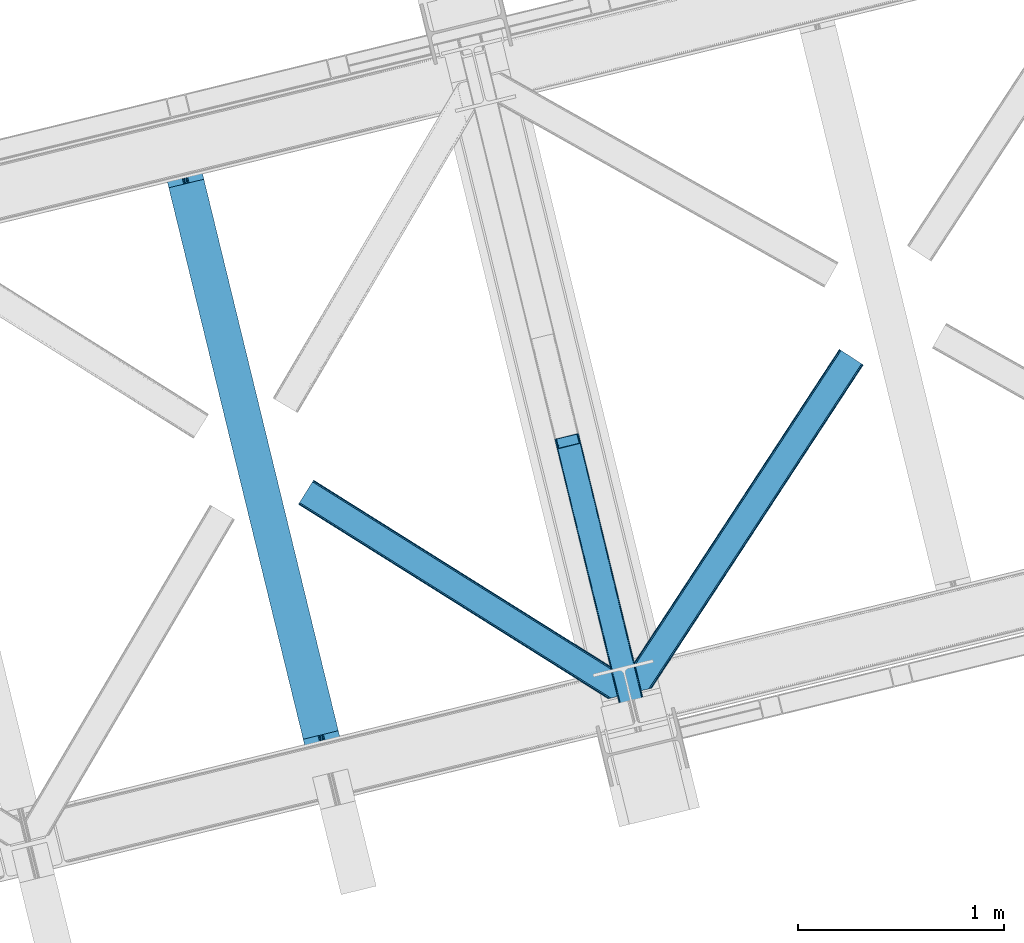
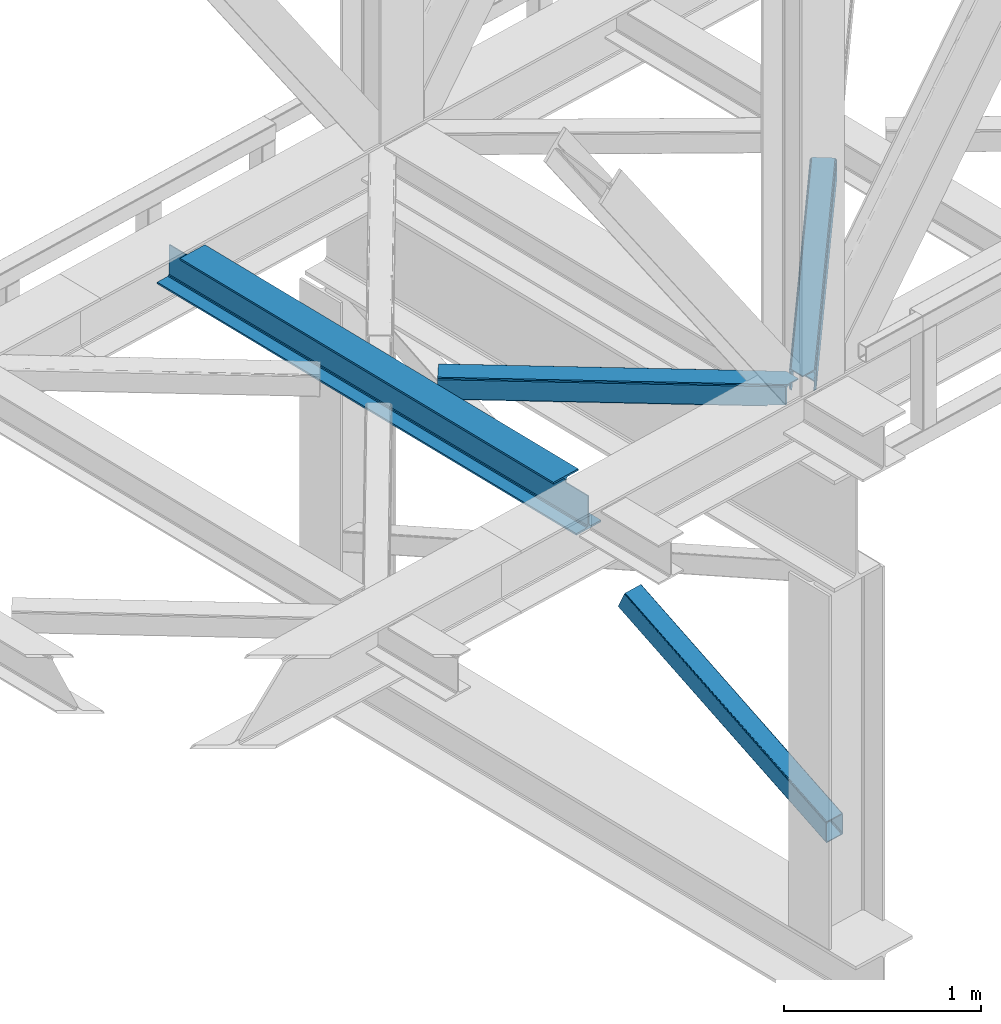
# One storey, part 37 of 92: 3 members, 1 beam.
"""IFC4 building model written with IfcOpenShell, lengths in millimetres."""

from ifc_helpers import new_model, entity, si_unit, converted_unit, derived_unit, direction, frame, origin, place, context, subcontext, project, spatial, triangles, polygons, material, type_object, element, save


model = new_model("IFC4")

# Units and contexts
model_context = context("Model", 3, precision=0.01, world=origin(), true_north=direction((6.12303176911189e-17, 1.0)))
plan_context = context("Plan", 3, precision=0.01, world=origin(), true_north=direction((6.12303176911189e-17, 1.0)))
body_context = subcontext(model_context, "Body", "Model", "MODEL_VIEW")
ifc_project = project(units=[si_unit("LENGTHUNIT", "METRE", prefix="MILLI"), si_unit("AREAUNIT", "SQUARE_METRE"), si_unit("VOLUMEUNIT", "CUBIC_METRE"), converted_unit("PLANEANGLEUNIT", "DEGREE", entity("IfcRatioMeasure", 0.0174532925199433), si_unit("PLANEANGLEUNIT", "RADIAN"), dimensions=[0, 0, 0, 0, 0, 0, 0]), si_unit("MASSUNIT", "GRAM", prefix="KILO"), derived_unit("MASSDENSITYUNIT", [(si_unit("MASSUNIT", "GRAM", prefix="KILO"), 1), (si_unit("LENGTHUNIT", "METRE"), -3)]), derived_unit("MOMENTOFINERTIAUNIT", [(si_unit("LENGTHUNIT", "METRE"), 4)]), si_unit("TIMEUNIT", "SECOND"), si_unit("FREQUENCYUNIT", "HERTZ"), si_unit("THERMODYNAMICTEMPERATUREUNIT", "DEGREE_CELSIUS"), derived_unit("THERMALTRANSMITTANCEUNIT", [(si_unit("MASSUNIT", "GRAM", prefix="KILO"), 1), (si_unit("THERMODYNAMICTEMPERATUREUNIT", "KELVIN"), -1), (si_unit("TIMEUNIT", "SECOND"), -3)]), derived_unit("VOLUMETRICFLOWRATEUNIT", [(si_unit("LENGTHUNIT", "METRE"), 3), (si_unit("TIMEUNIT", "SECOND"), -1)]), derived_unit("MASSFLOWRATEUNIT", [(si_unit("MASSUNIT", "GRAM", prefix="KILO"), 1), (si_unit("TIMEUNIT", "SECOND"), -1)]), derived_unit("ROTATIONALFREQUENCYUNIT", [(si_unit("TIMEUNIT", "SECOND"), -1)]), si_unit("ELECTRICCURRENTUNIT", "AMPERE"), si_unit("ELECTRICVOLTAGEUNIT", "VOLT"), si_unit("POWERUNIT", "WATT"), si_unit("FORCEUNIT", "NEWTON", prefix="KILO"), si_unit("ILLUMINANCEUNIT", "LUX"), si_unit("LUMINOUSFLUXUNIT", "LUMEN"), si_unit("LUMINOUSINTENSITYUNIT", "CANDELA"), derived_unit("USERDEFINED", [(si_unit("MASSUNIT", "GRAM", prefix="KILO"), -1), (si_unit("LENGTHUNIT", "METRE"), -2), (si_unit("TIMEUNIT", "SECOND"), 3), (si_unit("LUMINOUSFLUXUNIT", "LUMEN"), 1)]), derived_unit("LINEARVELOCITYUNIT", [(si_unit("LENGTHUNIT", "METRE"), 1), (si_unit("TIMEUNIT", "SECOND"), -1)]), si_unit("PRESSUREUNIT", "PASCAL"), derived_unit("USERDEFINED", [(si_unit("LENGTHUNIT", "METRE"), -2), (si_unit("MASSUNIT", "GRAM", prefix="KILO"), 1), (si_unit("TIMEUNIT", "SECOND"), -2)]), derived_unit("LINEARFORCEUNIT", [(si_unit("MASSUNIT", "GRAM", prefix="KILO"), 1), (si_unit("LENGTHUNIT", "METRE"), 1), (si_unit("TIMEUNIT", "SECOND"), -2), (si_unit("LENGTHUNIT", "METRE"), -1)]), derived_unit("PLANARFORCEUNIT", [(si_unit("MASSUNIT", "GRAM", prefix="KILO"), 1), (si_unit("LENGTHUNIT", "METRE"), 1), (si_unit("TIMEUNIT", "SECOND"), -2), (si_unit("LENGTHUNIT", "METRE"), -2)])], contexts=[model_context, plan_context])

# Site, building, storey
site_placement = place(None, origin())
site = spatial("IfcSite", under=ifc_project, at=site_placement, CompositionType="ELEMENT")
building_placement = place(site_placement, origin())
building = spatial("IfcBuilding", under=site, at=building_placement, CompositionType="ELEMENT")
storey_placement = place(building_placement, frame((0.0, 0.0, 15900.0)))
storey = spatial("IfcBuildingStorey", under=building, at=storey_placement, Name="05", CompositionType="ELEMENT", Elevation=15900.0)

# Beam
ifc_material = material(Name="Metal painted (White)")
beam_type = type_object("IfcBeamType", PredefinedType="BEAM")
beam_placement = place(storey_placement, frame((-50891.92, 5381.26, 3441.0)))
element("IfcBeam", 1, at=beam_placement, inside=storey, type_object=beam_type, material=ifc_material, ObjectType="Steel Beam", PredefinedType="BEAM", context=body_context, shape_type="Tessellation", body=[
    polygons([(900.98534618944, 41.4445662733081, 11.000000000004), (900.98534618944, 41.4445662733081, 2.16573425859679e-12), (170.021610174761, 3040.13999372697, 2.16573425859679e-12), (170.021610174761, 3040.13999372697, 11.000000000004), (834.919806235823, 25.3403919499656, 11.000000000004), (103.956070221144, 3024.03581940362, 11.000000000004), (828.971056214531, 23.8903211957385, 12.2179274798217), (98.0073201998513, 3022.5857486494, 12.2179274798217), (823.927949458422, 22.6610105689183, 15.6862915010192), (92.9642134437427, 3021.35643802258, 15.6862915010192), (820.558253255246, 21.8396114687119, 20.8770650821657), (89.5945172405668, 3020.53503892237, 20.8770650821657), (819.374973305552, 21.5511744621195, 27.0000000000047), (88.4112372908809, 3020.24660191578, 27.0000000000047), (81.6103728838888, 3018.58881926485, 27.0000000000047), (81.6103728838888, 3018.58881926485, 203.000000000006), (88.4112372908723, 3020.24660191578, 203.000000000006), (0.0, 2998.69542745366, 2.16573425859679e-12), (0.0, 2998.69542745366, 10.9999999999997), (66.0655399536172, 3014.799601777, 11.000000000004), (72.0142899749184, 3016.24967253123, 12.2179274798217), (77.057396731027, 3017.47898315805, 15.6862915010192), (80.4270929342029, 3018.30038225826, 20.8770650821657), (819.374973305552, 21.5511744621195, 203.000000000006), (812.574108898559, 19.8933918111876, 203.000000000006), (812.574108898559, 19.8933918111876, 27.0000000000047), (811.390828948873, 19.6049548045963, 20.8770650821657), (808.021132745689, 18.7835557043887, 15.6862915010192), (802.978025989589, 17.5542450775675, 12.2179274798217), (797.029275968288, 16.1041743233425, 11.000000000004), (730.963736014679, -1.08286712929839e-12, 10.9999999999997), (730.963736014679, -1.08286712929839e-12, 2.16573425859679e-12), (779.675212882749, 184.415062601691, 203.069791966819), (128.020401343512, 2857.75452019162, 203.000000000006), (128.243282132658, 2856.8401777572, 203.617301946336), (128.256196377177, 2856.7871977843, 217.000003693143), (779.530009633833, 185.010597404071, 217.000003676718), (779.530880241722, 185.007025963191, 204.00000679514), (772.96491171832, 182.385463974441, 203.006342981529), (772.742064056782, 183.299815969774, 203.617301946336), (772.729149812254, 183.352795942668, 217.000003693143), (121.455336555608, 2855.1293963229, 217.000003676718), (121.45446594771, 2855.13296776377, 204.00000679514), (121.310166358664, 2855.72494066435, 203.076120467494), (121.219536936511, 2856.09673754069, 203.000000000006), (780.713494357877, 185.298194377514, 223.122939328039), (784.082490766539, 186.122464201393, 228.313710402595), (789.125126170563, 187.353708426698, 231.782072735464), (795.073705041275, 188.80448128138, 232.999999602236), (861.13915590679, 204.909021065314, 232.999999283132), (861.137682570352, 204.915065042187, 243.999994005812), (691.116301666431, 163.469558245297, 243.999994827032), (691.117775002877, 163.463514268424, 233.000000104353), (757.183225868392, 179.568054052358, 232.999999785253), (763.132130996731, 181.017488520583, 231.782072861012), (768.175695503853, 182.244921343717, 228.313710479427), (771.546082413602, 183.063487001147, 223.12293937232), (120.271851831563, 2854.84179934945, 223.122939328039), (116.902855422893, 2854.01752952557, 228.313710402595), (111.860220018877, 2852.78628530027, 231.782072735464), (105.911641148165, 2851.33551244559, 232.999999602236), (39.8461902826419, 2835.23097266165, 232.999999283128), (39.8476636190794, 2835.22492868478, 243.999994005812), (209.869044522992, 2876.67043548167, 243.999994827032), (209.867571186554, 2876.67647945854, 233.000000104357), (143.802120321031, 2860.57193967461, 232.999999785253), (137.85321519271, 2859.12250520638, 231.782072861012), (132.809650685579, 2857.89507238325, 228.313710479427), (129.439263775838, 2857.07650672582, 223.12293937232)], [[[1, 2, 3, 4]], [[5, 1, 4, 6]], [[7, 5, 6, 8]], [[9, 7, 8, 10]], [[11, 9, 10, 12]], [[13, 11, 12, 14]], [[15, 16, 17, 14, 12, 10, 8, 6, 4, 3, 18, 19, 20, 21, 22, 23]], [[13, 24, 25, 26, 27, 28, 29, 30, 31, 32, 2, 1, 5, 7, 9, 11]], [[2, 32, 18, 3]], [[32, 31, 19, 18]], [[31, 30, 20, 19]], [[27, 26, 15, 23]], [[28, 27, 23, 22]], [[29, 28, 22, 21]], [[30, 29, 21, 20]], [[33, 24, 13, 14, 17, 34, 35, 36, 37, 38]], [[25, 39, 40, 41, 42, 43, 44, 16, 15, 26]], [[39, 25, 24, 33]], [[45, 34, 17, 16]], [[41, 40, 38, 37, 46, 47, 48, 49, 50, 51, 52, 53, 54, 55, 56, 57]], [[42, 58, 59, 60, 61, 62, 63, 64, 65, 66, 67, 68, 69, 36, 35, 43]], [[46, 37, 36, 69]], [[47, 46, 69, 68]], [[48, 47, 68, 67]], [[49, 48, 67, 66]], [[50, 49, 66, 65]], [[51, 50, 65, 64]], [[52, 51, 64, 63]], [[53, 52, 63, 62]], [[54, 53, 62, 61]], [[55, 54, 61, 60]], [[56, 55, 60, 59]], [[57, 56, 59, 58]], [[41, 57, 58, 42]]], closed=False),
])

# Members
member_type_1 = type_object("IfcMemberType", PredefinedType="BRACE")
member_1_placement = place(storey_placement, frame((-48982.34, 5508.87, 911.28)))
element("IfcMember", 2, at=member_1_placement, inside=storey, type_object=member_type_1, ObjectType="Steel Vertical Brace", PredefinedType="BRACE", context=body_context, shape_type="Tessellation", body=[
    triangles([(109.104968261716, 1516.67777252197, 692.224026489257), (472.287451171876, 26.761738586426, 0.0), (369.303039550781, 1.65803833007885, 0.0), (6.11590576171875, 1491.57407226563, 692.224026489257), (115.806884765625, 1516.48185424805, 696.163320922849), (116.583581542967, 1515.53714447022, 698.605032348631), (479.087036132813, 28.4191955566412, 7.68092651366896), (114.109313964844, 1517.03065795899, 694.092517089841), (478.091748046871, 28.1761871337894, 4.96481323242188), (111.755969238278, 1517.09925842285, 692.710043334959), (477.096459960936, 27.9337600708013, 2.24986267089844), (474.691955566406, 27.3477493286136, 1.12551269531104), (126.913183593751, 1473.16763763428, 795.217739868163), (479.087036132813, 28.4191955566412, 123.979641723632), (123.345959472652, 1469.55971832275, 801.112728881835), (120.797277832033, 1468.71209564209, 801.59758300781), (472.287451171876, 26.761738586426, 131.659405517577), (125.406298828122, 1470.70383453369, 799.729092407226), (474.691955566406, 27.3477493286136, 130.53505554199), (126.657385253908, 1471.97061767578, 797.659451293945), (477.096459960936, 27.9337600708013, 129.409542846679), (478.091748046871, 28.1761871337894, 126.694592285156), (369.303039550781, 1.65803833007885, 131.659405517577), (17.8082153320283, 1443.60839538574, 801.59758300781), (10.3296020507769, 1444.74844207764, 795.217739868163), (362.498803710936, 0.0, 123.979641723632), (363.494091796871, 0.243008422851744, 126.694592285156), (11.1062988281265, 1443.80431365967, 797.659451293945), (364.494030761714, 0.486016845703489, 129.409542846679), (12.7992187499985, 1443.25550994873, 799.729092407226), (366.898535156251, 1.07202758789117, 130.53505554199), (15.1572143554658, 1443.18690948486, 801.112728881835), (0.0, 1487.11853027344, 698.605032348631), (362.498803710936, 0.0, 7.68092651366896), (366.898535156251, 1.07202758789117, 1.12551269531104), (3.56722412109229, 1490.72644958496, 692.710043334959), (364.494030761714, 0.486016845703489, 2.24986267089844), (1.50688476562209, 1489.58233337402, 694.092517089841), (363.494091796871, 0.243008422851744, 4.96481323242188), (0.25579833984375, 1488.31496887207, 696.163320922849), (112.216406250001, 1512.35478057861, 703.161730957028), (111.43505859375, 1513.29949035645, 700.720019531247), (109.742138671871, 1513.84771270752, 698.650378417966), (104.733142089841, 1513.49482727051, 696.781887817382), (107.384143066403, 1513.91631317139, 697.266741943356), (120.057788085935, 1471.51831970215, 795.172393798828), (121.569323730466, 1473.98212280273, 790.661041259766), (121.313525390622, 1472.7856842041, 793.102752685547), (118.002099609374, 1470.37362213135, 796.55486755371), (115.448767089845, 1469.52599945068, 797.040884399412), (6.85539550780959, 1488.76784820557, 698.650378417966), (5.59965820312209, 1487.50048370361, 700.720019531247), (11.4644165039063, 1490.75958709717, 696.781887817382), (8.91108398437063, 1489.91254577637, 697.266741943356), (5.34385986327834, 1486.30404510498, 703.161730957028), (17.1710449218735, 1446.4384552002, 795.172393798828), (19.5290405273408, 1446.36985473633, 796.55486755371), (15.4781250000015, 1446.98667755127, 793.102752685547), (22.1800415039033, 1446.79075927734, 797.040884399412), (14.69677734375, 1447.9313873291, 790.661041259766), (371.754052734374, 2.2562576293949, 125.048181152342), (374.158557128903, 2.84226837158258, 126.173693847653), (369.349548339844, 1.66966552734448, 123.923831176755), (367.358972167967, 1.18423004150463, 118.492767333984), (368.354260253902, 1.42723846435547, 121.208880615231), (472.236291503905, 26.7495300292976, 123.923831176755), (467.427282714845, 25.5775085449222, 126.173693847653), (469.831787109375, 26.1635192871099, 125.048181152342), (473.231579589839, 26.9925384521484, 121.208880615231), (474.226867675781, 27.2349655151374, 118.492767333984), (369.349548339844, 1.66966552734448, 7.73557434081886), (371.754052734374, 2.2562576293949, 6.61122436523146), (367.358972167967, 1.18423004150463, 13.166638183593), (368.354260253902, 1.42723846435547, 10.4505249023423), (374.158557128903, 2.84226837158258, 5.48571166992042), (472.236291503905, 26.7495300292976, 7.73557434081886), (473.231579589839, 26.9925384521484, 10.4505249023423), (469.831787109375, 26.1635192871099, 6.61122436523146), (474.226867675781, 27.2349655151374, 13.166638183593), (467.427282714845, 25.5775085449222, 5.48571166992042)], [[1, 2, 3], [3, 4, 1], [5, 6, 7], [8, 5, 9], [10, 8, 11], [1, 10, 12], [12, 2, 1], [11, 12, 10], [9, 11, 8], [7, 9, 5], [6, 13, 14], [14, 7, 6], [15, 16, 17], [18, 15, 19], [20, 18, 21], [13, 20, 22], [22, 14, 13], [21, 22, 20], [19, 21, 18], [17, 19, 15], [17, 16, 23], [24, 23, 16], [25, 26, 27], [28, 27, 29], [30, 29, 31], [32, 31, 23], [23, 24, 32], [31, 32, 30], [29, 30, 28], [27, 28, 25], [25, 33, 26], [34, 26, 33], [4, 3, 35], [36, 35, 37], [38, 37, 39], [40, 39, 34], [34, 33, 40], [39, 40, 38], [37, 38, 36], [35, 36, 4], [41, 6, 42], [43, 5, 8], [8, 10, 43], [6, 41, 13], [6, 5, 43], [43, 42, 6], [44, 1, 4], [1, 45, 43], [44, 45, 1], [1, 43, 10], [18, 46, 15], [47, 13, 41], [46, 20, 13], [48, 13, 47], [20, 46, 18], [46, 16, 15], [13, 48, 46], [46, 49, 16], [16, 50, 24], [50, 16, 49], [51, 33, 52], [4, 53, 44], [54, 4, 51], [4, 54, 53], [51, 4, 36], [55, 52, 33], [36, 38, 51], [40, 51, 38], [55, 33, 25], [40, 33, 51], [56, 32, 24], [57, 56, 24], [58, 25, 56], [59, 24, 50], [24, 59, 57], [30, 32, 56], [25, 60, 55], [28, 56, 25], [60, 25, 58], [56, 28, 30], [61, 62, 23], [27, 63, 31], [27, 31, 29], [23, 62, 17], [23, 31, 61], [63, 61, 31], [64, 26, 34], [26, 65, 63], [64, 65, 26], [26, 63, 27], [19, 66, 22], [67, 17, 62], [68, 19, 17], [68, 17, 67], [22, 21, 19], [66, 14, 22], [19, 68, 66], [66, 69, 14], [14, 70, 7], [70, 14, 69], [71, 35, 72], [34, 73, 64], [74, 34, 71], [34, 74, 73], [71, 34, 39], [72, 3, 75], [71, 39, 35], [35, 39, 37], [75, 3, 2], [35, 3, 72], [76, 9, 7], [77, 76, 7], [78, 12, 76], [79, 7, 70], [7, 79, 77], [12, 9, 76], [2, 80, 75], [12, 78, 2], [80, 2, 78], [11, 9, 12], [80, 44, 75], [53, 75, 44], [44, 80, 78], [45, 78, 76], [43, 76, 77], [42, 77, 79], [79, 41, 42], [77, 42, 43], [76, 43, 45], [78, 45, 44], [47, 41, 70], [79, 70, 41], [47, 70, 69], [48, 69, 66], [46, 66, 68], [49, 68, 67], [67, 50, 49], [68, 49, 46], [66, 46, 48], [69, 48, 47], [50, 67, 59], [62, 59, 67], [57, 59, 62], [56, 57, 61], [58, 56, 63], [60, 58, 65], [65, 64, 60], [63, 65, 58], [61, 63, 56], [62, 61, 57], [55, 60, 64], [64, 73, 55], [52, 55, 73], [51, 52, 74], [54, 51, 71], [53, 54, 72], [72, 75, 53], [71, 72, 54], [74, 71, 51], [73, 74, 52]]),
])
member_type_2 = type_object("IfcMemberType", PredefinedType="BRACE")
member_2_placement = place(storey_placement, frame((-48630.06, 5769.52, 3511.0)))
element("IfcMember", 3, at=member_2_placement, inside=storey, type_object=member_type_2, ObjectType="Steel Horizontal Brace", PredefinedType="BRACE", context=body_context, shape_type="Tessellation", body=[
    triangles([(109.770043945311, 259.949830627442, 7.52047119140843), (115.030187988275, 238.365682983398, 7.77510681152489), (114.216284179682, 239.94640045166, 8.3320495605476), (108.807312011719, 259.662057495118, 8.52041015625218), (113.6349243164, 239.859777832031, 8.52041015625218), (112.207104492183, 237.677352905273, 8.52041015625218), (91.0363037109346, 232.516621398926, 8.52041015625218), (109.532849121089, 237.025648498535, 9.50058288574292), (90.2596069335923, 232.32767944336, 9.50058288574292), (5.01829833984084, 77.405158996582, 9.50058288574292), (0.62786865234375, 95.4308029174808, 9.50058288574292), (1046.62448730468, 1651.75324859619, 6.99957275390625), (1041.02017822265, 1655.42221069336, 8.3320495605476), (116.699853515624, 231.514356994629, 6.99957275390625), (1036.27163085937, 1658.53190460205, 12.1260040283232), (3.92999267578125, 81.8752349853512, 12.1260040283232), (1033.0950805664, 1660.61026611328, 17.8035644531265), (2.70216064452688, 86.9220199584961, 17.8035644531265), (1031.98352050781, 1661.3398727417, 24.4996673583992), (2.26962890624418, 88.6940048217775, 24.4996673583992), (1122.75472412109, 1601.90454711914, 6.99957275390625), (146.20968017578, 110.458955383301, 6.99957275390625), (1031.98352050781, 1661.3398727417, 115.501089477541), (2.26962890624418, 88.6940048217775, 115.501089477541), (1033.0950805664, 1660.61026611328, 122.196029663086), (2.70216064452688, 86.9220199584961, 122.196029663086), (1036.27163085937, 1658.53190460205, 127.87475280762), (3.92999267578125, 81.8752349853512, 127.87475280762), (1041.02017822265, 1655.42221069336, 131.667544555665), (5.77174072265188, 74.322789001465, 131.667544555665), (1046.62448730468, 1651.75324859619, 133.000021362306), (7.94370117186918, 65.4140304565426, 133.000021362306), (1027.23962402344, 1664.44433441162, 10.8028289794929), (0.520898437498545, 95.8714736938473, 10.8691040039084), (0.0, 98.0056457519531, 17.5000946044929), (1035.16472167968, 1659.2562789917, 1.33247680664135), (112.258264160155, 249.73533782959, 1.33247680664135), (110.542089843744, 256.771536254882, 5.59500732422021), (109.077062988275, 259.839372253418, 8.31925964355469), (1030.4161743164, 1662.36655426025, 5.12526855468968), (1040.76903076172, 1655.58789825439, 0.0), (114.430224609372, 240.826579284668, 0.0), (1026.12806396484, 1665.1745223999, 17.5000946044929), (1128.61018066406, 1598.06989746094, 0.0), (148.479309082031, 101.147314453125, 0.0), (150.651269531249, 92.2385559082031, 1.33247680664135), (148.507214355464, 101.029298400879, 8.50064392089917), (152.488366699217, 84.686109924316, 5.12526855468968), (153.344128417964, 81.1822540283201, 8.50064392089917), (1026.12806396484, 1665.1745223999, 122.500662231447), (0.0, 98.0056457519531, 122.500662231447), (1040.76903076172, 1655.58789825439, 139.999594116212), (1035.16472167968, 1659.2562789917, 138.667117309571), (3.50211181640043, 83.6350112915043, 138.667117309571), (5.674072265625, 74.7262527465818, 139.999594116212), (1030.4161743164, 1662.36655426025, 134.874325561526), (1.66036376952979, 91.1874572753904, 134.874325561526), (1027.23962402344, 1664.44433441162, 129.197927856447), (0.432531738275429, 96.2336608886717, 129.197927856447), (23.8869140624956, 0.0, 139.999594116212), (23.8869140624956, 0.0, 133.000021362306), (1128.61018066406, 1598.06989746094, 139.999594116212), (93.3338378906192, 16.9280364990236, 139.999594116212), (1122.75472412109, 1601.90454711914, 133.000021362306), (83.3763061523423, 14.5008590698244, 133.000021362306), (1143.25114746093, 1588.48385467529, 122.500662231447), (1142.13958740234, 1589.21346130371, 129.197927856447), (118.225341796875, 22.9951080322262, 122.500662231447), (116.327783203124, 22.5335083007813, 129.197927856447), (1138.96303710937, 1591.29182281494, 134.874325561526), (110.932763671874, 21.2184722900392, 134.874325561526), (1134.21448974609, 1594.4020980835, 138.667117309571), (102.858837890621, 19.2499877929686, 138.667117309571), (1143.25114746093, 1588.48385467529, 17.5000946044929), (118.225341796875, 22.9951080322262, 17.5000946044929), (1142.13958740234, 1589.21346130371, 10.8028289794929), (1133.1075805664, 1595.12647247314, 12.1260040283232), (1136.27947998047, 1593.04811096191, 17.8035644531265), (1137.39569091797, 1592.3185043335, 24.4996673583992), (1138.96303710937, 1591.29182281494, 5.12526855468968), (1134.21448974609, 1594.4020980835, 1.33247680664135), (1128.35903320312, 1598.23616638184, 8.3320495605476), (1133.1075805664, 1595.12647247314, 127.87475280762), (1137.39569091797, 1592.3185043335, 115.501089477541), (1136.27947998047, 1593.04811096191, 122.196029663086), (1128.35903320312, 1598.23616638184, 131.667544555665), (92.9013061523438, 16.8228103637693, 131.667544555665), (100.979882812499, 18.79129486084, 127.87475280762), (106.374902343749, 20.106330871582, 122.196029663086), (108.267810058591, 20.5685119628906, 115.501089477541), (108.267810058591, 20.5685119628906, 24.4996673583992), (100.979882812499, 18.79129486084, 12.1260040283232), (115.472021484369, 22.32421875, 9.50058288574292), (106.374902343749, 20.106330871582, 17.8035644531265), (96.1987792968721, 17.6262496948239, 9.50058288574292), (115.941760253903, 22.4393280029299, 10.8702667236357), (153.060424804688, 80.2392883300781, 9.00061340332104), (152.776721191403, 79.2969039916989, 9.50058288574292), (148.711853027344, 99.8677413940432, 8.8831787109375), (148.600231933589, 99.023606872559, 9.08781738281323), (148.493261718744, 98.1672637939455, 9.29478149414354), (148.381640624997, 97.3225479125977, 9.50058288574292)], [[1, 2, 3], [4, 5, 6], [6, 7, 4], [7, 6, 8], [8, 9, 7], [9, 8, 10], [10, 11, 9], [12, 13, 3], [3, 2, 12], [2, 14, 12], [15, 16, 8], [8, 13, 15], [8, 5, 13], [16, 10, 8], [8, 6, 5], [15, 17, 18], [18, 16, 15], [17, 19, 20], [20, 18, 17], [21, 12, 14], [14, 22, 21], [19, 23, 20], [24, 20, 23], [23, 25, 24], [26, 24, 25], [25, 27, 26], [28, 26, 27], [27, 29, 28], [30, 28, 29], [29, 31, 30], [32, 30, 31], [33, 34, 35], [36, 37, 38], [33, 4, 9], [33, 1, 39], [9, 34, 33], [9, 11, 34], [4, 7, 9], [40, 38, 1], [1, 33, 40], [38, 40, 36], [36, 41, 37], [42, 37, 41], [35, 43, 33], [41, 44, 42], [45, 42, 44], [14, 42, 22], [37, 2, 38], [2, 37, 42], [38, 2, 1], [42, 14, 2], [22, 42, 45], [46, 47, 45], [47, 46, 48], [45, 47, 22], [48, 49, 47], [50, 43, 35], [35, 51, 50], [52, 53, 54], [54, 55, 52], [53, 56, 57], [57, 54, 53], [56, 58, 59], [59, 57, 56], [58, 50, 51], [51, 59, 58], [28, 57, 26], [30, 32, 55], [32, 60, 55], [32, 61, 60], [54, 30, 55], [28, 54, 57], [16, 11, 10], [28, 30, 54], [51, 35, 20], [24, 26, 51], [24, 51, 20], [57, 59, 26], [26, 59, 51], [35, 18, 20], [18, 11, 16], [11, 18, 34], [35, 34, 18], [62, 55, 63], [62, 52, 55], [55, 60, 63], [64, 32, 31], [32, 64, 65], [61, 32, 65], [66, 67, 68], [69, 68, 67], [67, 70, 69], [71, 69, 70], [70, 72, 71], [73, 71, 72], [72, 62, 73], [63, 73, 62], [74, 66, 68], [68, 75, 74], [76, 77, 78], [79, 66, 74], [76, 78, 74], [76, 80, 77], [78, 79, 74], [77, 80, 81], [21, 44, 41], [44, 82, 81], [82, 44, 21], [82, 77, 81], [67, 83, 70], [84, 66, 79], [66, 85, 67], [85, 66, 84], [67, 85, 83], [62, 64, 52], [72, 70, 83], [83, 86, 72], [86, 64, 62], [62, 72, 86], [15, 36, 40], [41, 12, 21], [41, 13, 12], [13, 41, 36], [15, 13, 36], [19, 43, 50], [33, 17, 15], [40, 33, 15], [17, 33, 43], [19, 17, 43], [53, 27, 56], [52, 64, 31], [31, 29, 52], [29, 27, 53], [53, 52, 29], [58, 56, 27], [50, 23, 19], [25, 50, 58], [50, 25, 23], [25, 58, 27], [64, 86, 87], [87, 65, 64], [86, 83, 88], [88, 87, 86], [83, 85, 89], [89, 88, 83], [85, 84, 90], [90, 89, 85], [84, 79, 91], [91, 90, 84], [89, 68, 69], [87, 73, 63], [60, 65, 63], [65, 60, 61], [65, 87, 63], [88, 73, 87], [88, 89, 71], [71, 73, 88], [69, 71, 89], [91, 75, 68], [92, 93, 94], [89, 90, 68], [92, 95, 93], [91, 94, 75], [90, 91, 68], [96, 75, 94], [94, 93, 96], [76, 74, 75], [49, 80, 97], [98, 97, 80], [49, 48, 80], [76, 96, 98], [98, 80, 76], [96, 93, 98], [44, 81, 45], [46, 45, 81], [81, 80, 46], [48, 46, 80], [75, 96, 76], [82, 21, 22], [77, 82, 47], [47, 99, 77], [77, 100, 101], [100, 77, 99], [101, 102, 77], [77, 102, 92], [95, 92, 102], [22, 47, 82], [79, 78, 91], [94, 91, 78], [78, 77, 94], [92, 94, 77], [102, 101, 98], [101, 100, 97], [100, 99, 49], [99, 47, 49], [102, 98, 93], [93, 95, 102]]),
])
member_type_3 = type_object("IfcMemberType", PredefinedType="BRACE")
member_3_placement = place(storey_placement, frame((-50224.54, 5740.78, 3511.0)))
element("IfcMember", 4, at=member_3_placement, inside=storey, type_object=member_type_3, ObjectType="Steel Horizontal Brace", PredefinedType="BRACE", context=body_context, shape_type="Tessellation", body=[
    triangles([(9.3017578125, 956.602075195313, 0.0), (65.121606445311, 1045.5350189209, 0.0), (1381.50172119141, 219.29300994873, 0.0), (1417.17861328125, 72.9298507690428, 0.0), (1422.67130126953, 50.3934356689451, 10.8028289794929), (1423.12708740235, 48.5365722656252, 17.5000946044929), (0.0, 941.779724121094, 17.5000946044929), (0.706933593748545, 942.908143615723, 10.8028289794929), (1421.3830078125, 55.6809036254881, 5.12526855468968), (2.72076416015625, 946.121319580078, 5.12526855468968), (1419.45289306641, 63.5949554443359, 1.33247680664135), (5.73918457031687, 950.929747009277, 1.33247680664135), (68.6795288085923, 1051.20734710693, 1.33247680664135), (71.6979492187529, 1056.016355896, 5.12526855468968), (1377.30662841797, 236.497192382813, 5.17061462402489), (73.7164306640625, 1059.22895050049, 10.8028289794929), (1382.10168457031, 238.005239868164, 10.8028289794929), (1383.90622558594, 238.445329284668, 17.5000946044929), (74.423364257811, 1060.35736999512, 17.5000946044929), (1379.22744140625, 228.627905273437, 1.33247680664135), (1377.23221435547, 236.818103027344, 17.5198608398459), (1383.90622558594, 238.445329284668, 18.5197998046897), (1378.19959716797, 237.054716491699, 18.5197998046897), (1379.50649414062, 231.698066711426, 18.5197998046897), (1563.91384277344, 125.462109375, 18.5197998046897), (1566.64855957031, 114.236050415039, 18.5197998046897), (1563.91384277344, 125.462109375, 122.500662231447), (74.423364257811, 1060.35736999512, 122.500662231447), (1564.36497802735, 123.605245971679, 129.197927856447), (73.7164306640625, 1059.22895050049, 129.197927856447), (1565.65327148438, 118.317196655274, 134.874325561526), (71.6979492187529, 1056.016355896, 134.874325561526), (1567.58338623047, 110.403144836426, 138.667117309571), (68.6795288085923, 1051.20734710693, 138.667117309571), (1569.85766601563, 101.068249511719, 139.999594116212), (65.121606445311, 1045.5350189209, 139.999594116212), (67.9772460937529, 1050.08706665039, 12.1260040283232), (1379.67392578125, 226.784413146973, 12.1260040283232), (1378.42749023438, 231.905030822754, 17.5198608398459), (69.9957275390625, 1053.30024261475, 17.8035644531265), (1566.29044189453, 115.704565429687, 24.4996673583992), (70.702661132811, 1054.42866210938, 24.4996673583992), (1381.60404052735, 218.870361328125, 8.3320495605476), (64.9588256835923, 1045.27863922119, 8.3320495605476), (1383.8783203125, 209.535466003418, 6.99957275390625), (61.400903320311, 1039.60631103516, 6.99957275390625), (13.0224609375, 962.530783081054, 6.99957275390625), (1414.80201416016, 82.6873947143558, 6.99957275390625), (1419.00640869141, 65.4384475708011, 12.1260040283232), (1420.25284423828, 60.3178298950197, 17.5198608398459), (1417.07629394531, 73.3524993896481, 8.3320495605476), (1566.29044189453, 115.704565429687, 115.501089477541), (70.702661132811, 1054.42866210938, 115.501089477541), (1569.95998535156, 100.646182250976, 131.667544555665), (1572.23891601562, 91.3107055664059, 133.000021362306), (61.400903320311, 1039.60631103516, 133.000021362306), (64.9588256835923, 1045.27863922119, 131.667544555665), (1568.03452148438, 108.559652709961, 127.87475280762), (67.9772460937529, 1050.08706665039, 127.87475280762), (1566.74157714844, 113.847702026367, 122.196029663086), (69.9957275390625, 1053.30024261475, 122.196029663086), (1589.21927490235, 21.6376327514645, 133.000021362306), (1589.21927490235, 21.6376327514645, 139.999594116212), (9.3017578125, 956.602075195313, 139.999594116212), (1524.16278076172, 5.77929840087927, 139.999594116212), (1515.09356689453, 3.56780548095685, 138.667117309571), (5.73918457031687, 950.929747009277, 138.667117309571), (1507.4010131836, 1.69291992187482, 134.874325561526), (2.72076416015625, 946.121319580078, 134.874325561526), (1502.26179199219, 0.439508056640989, 129.197927856447), (0.706933593748545, 942.908143615723, 129.197927856447), (1500.45260009765, 0.0, 122.500662231447), (0.0, 941.779724121094, 122.500662231447), (1424.34096679687, 47.7738281250004, 18.5197998046897), (1500.45260009765, 0.0, 18.5197998046897), (1421.60625, 58.9993057250977, 18.5197998046897), (1511.36821289063, 2.65972137451172, 18.5197998046897), (3.720703125, 947.708432006836, 24.4996673583992), (1509.9403930664, 2.31148681640661, 24.4996673583992), (4.42763671874854, 948.836851501464, 17.8035644531265), (1420.92722167969, 59.6585678100582, 18.0198303222678), (6.44611816406541, 952.050027465821, 12.1260040283232), (9.45988769531687, 956.858454895019, 8.3320495605476), (6.44611816406541, 952.050027465821, 127.87475280762), (13.0224609375, 962.530783081054, 133.000021362306), (9.45988769531687, 956.858454895019, 131.667544555665), (3.720703125, 947.708432006836, 115.501089477541), (4.42763671874854, 948.836851501464, 122.196029663086), (1524.57670898438, 5.87929229736346, 131.667544555665), (1516.88415527344, 4.00440673828143, 127.87475280762), (1511.74493408203, 2.75157623291034, 122.196029663086), (1533.65057373047, 8.09136657714862, 133.000021362306), (1509.9403930664, 2.31148681640661, 115.501089477541)], [[1, 2, 3], [3, 4, 1], [5, 6, 7], [7, 8, 5], [9, 5, 8], [8, 10, 9], [11, 9, 10], [10, 12, 11], [4, 11, 12], [12, 1, 4], [13, 14, 15], [16, 17, 15], [15, 14, 16], [18, 17, 19], [16, 19, 17], [20, 3, 2], [2, 13, 20], [15, 20, 13], [18, 21, 17], [18, 22, 23], [17, 21, 15], [21, 18, 23], [24, 22, 25], [22, 24, 23], [25, 26, 24], [25, 22, 27], [19, 22, 18], [22, 28, 27], [19, 28, 22], [29, 27, 30], [28, 30, 27], [31, 29, 32], [30, 32, 29], [33, 31, 34], [32, 34, 31], [35, 33, 36], [34, 36, 33], [37, 38, 39], [39, 40, 37], [24, 41, 42], [24, 26, 41], [42, 40, 39], [43, 38, 44], [37, 44, 38], [45, 43, 46], [44, 46, 43], [46, 47, 45], [48, 45, 47], [3, 48, 4], [43, 20, 38], [39, 15, 21], [15, 39, 38], [38, 20, 15], [43, 3, 20], [3, 45, 48], [43, 45, 3], [9, 49, 50], [50, 5, 9], [6, 5, 50], [49, 11, 51], [51, 4, 48], [4, 51, 11], [49, 9, 11], [41, 52, 53], [53, 42, 41], [54, 55, 56], [56, 57, 54], [58, 54, 57], [57, 59, 58], [60, 58, 59], [59, 61, 60], [52, 60, 61], [61, 53, 52], [58, 31, 33], [58, 33, 54], [55, 54, 35], [60, 31, 58], [62, 55, 63], [35, 63, 55], [54, 33, 35], [29, 31, 60], [25, 27, 52], [41, 25, 52], [25, 41, 26], [29, 60, 27], [60, 52, 27], [64, 35, 36], [35, 64, 65], [63, 35, 65], [66, 65, 64], [64, 67, 66], [68, 66, 67], [67, 69, 68], [70, 68, 69], [69, 71, 70], [72, 70, 71], [71, 73, 72], [74, 72, 6], [74, 75, 72], [73, 6, 72], [73, 7, 6], [74, 76, 77], [77, 75, 74], [78, 79, 76], [76, 80, 78], [76, 81, 80], [79, 77, 76], [50, 82, 80], [50, 49, 82], [51, 48, 83], [47, 83, 48], [49, 51, 82], [83, 82, 51], [16, 37, 40], [42, 28, 19], [16, 40, 19], [16, 14, 37], [40, 42, 19], [37, 14, 13], [46, 2, 1], [2, 44, 13], [44, 2, 46], [44, 37, 13], [30, 59, 32], [53, 28, 42], [28, 61, 30], [61, 28, 53], [30, 61, 59], [36, 56, 64], [34, 32, 59], [59, 57, 34], [57, 56, 36], [36, 34, 57], [82, 12, 10], [1, 47, 46], [1, 83, 47], [83, 1, 12], [82, 83, 12], [78, 7, 73], [8, 80, 82], [10, 8, 82], [80, 8, 7], [78, 80, 7], [67, 84, 69], [64, 56, 85], [85, 86, 64], [86, 84, 67], [67, 64, 86], [71, 69, 84], [73, 87, 78], [88, 73, 71], [73, 88, 87], [88, 71, 84], [89, 65, 66], [90, 66, 68], [91, 68, 70], [92, 63, 65], [89, 66, 90], [62, 63, 92], [89, 92, 65], [91, 90, 68], [72, 93, 91], [93, 72, 75], [79, 75, 77], [75, 79, 93], [72, 91, 70], [85, 55, 92], [85, 56, 55], [55, 62, 92], [91, 93, 88], [87, 88, 93], [90, 91, 84], [88, 84, 91], [89, 90, 86], [84, 86, 90], [92, 89, 85], [86, 85, 89], [93, 79, 78], [78, 87, 93]]),
])

save(model, "model.ifc")
